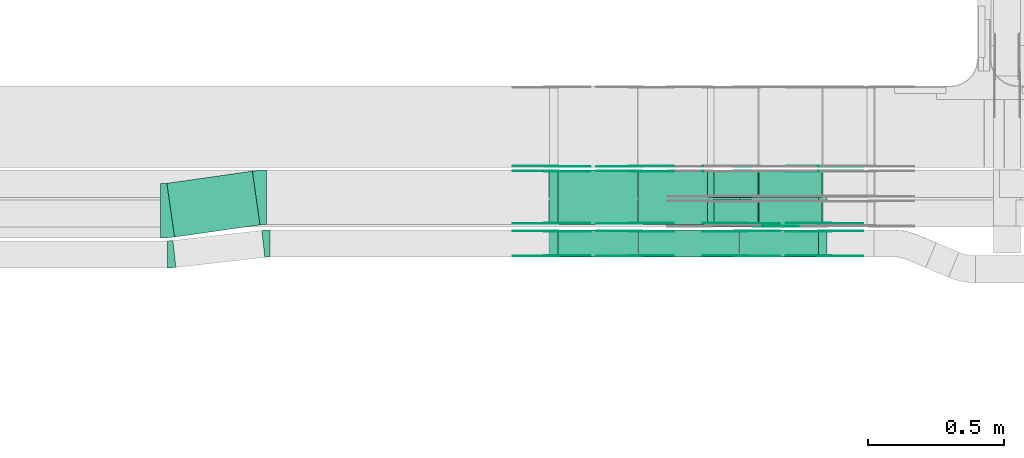
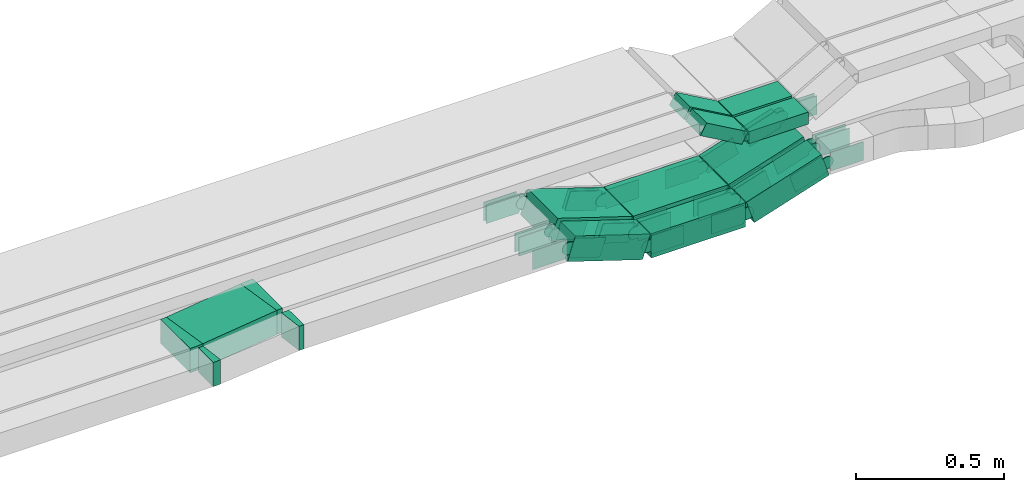
# One storey, part 10 of 27: 45 flow fittings, 11 flow segments.
"""IFC2X3 building model written with IfcOpenShell, lengths in millimetres."""

from ifc_helpers import new_model, entity, si_unit, converted_unit, derived_unit, direction, frame, frame_2d, origin, origin_2d_with_axis, place, context, subcontext, project, spatial, polyline, circle_curve, parameter, trimmed, segment, composite_curve, rectangle, outline, extrude, source, transform, mapped, material, type_object, type_shapes, element, save


model = new_model("IFC2X3")

# Units and contexts
model_context = context("Model", 3, precision=0.01, world=origin(), true_north=direction((6.12303176911189e-17, 1.0)))
body_context = subcontext(model_context, "Body", "Model", "MODEL_VIEW")
ifc_project = project(units=[si_unit("LENGTHUNIT", "METRE", prefix="MILLI"), si_unit("AREAUNIT", "SQUARE_METRE"), si_unit("VOLUMEUNIT", "CUBIC_METRE"), converted_unit("PLANEANGLEUNIT", "DEGREE", entity("IfcRatioMeasure", 0.0174532925199433), si_unit("PLANEANGLEUNIT", "RADIAN"), dimensions=[0, 0, 0, 0, 0, 0, 0]), si_unit("MASSUNIT", "GRAM", prefix="KILO"), derived_unit("MASSDENSITYUNIT", [(si_unit("MASSUNIT", "GRAM", prefix="KILO"), 1), (si_unit("LENGTHUNIT", "METRE"), -3)]), derived_unit("MOMENTOFINERTIAUNIT", [(si_unit("LENGTHUNIT", "METRE"), 4)]), si_unit("TIMEUNIT", "SECOND"), si_unit("FREQUENCYUNIT", "HERTZ"), si_unit("THERMODYNAMICTEMPERATUREUNIT", "DEGREE_CELSIUS"), derived_unit("THERMALTRANSMITTANCEUNIT", [(si_unit("MASSUNIT", "GRAM", prefix="KILO"), 1), (si_unit("THERMODYNAMICTEMPERATUREUNIT", "KELVIN"), -1), (si_unit("TIMEUNIT", "SECOND"), -3)]), derived_unit("VOLUMETRICFLOWRATEUNIT", [(si_unit("LENGTHUNIT", "METRE"), 3), (si_unit("TIMEUNIT", "SECOND"), -1)]), derived_unit("MASSFLOWRATEUNIT", [(si_unit("MASSUNIT", "GRAM", prefix="KILO"), 1), (si_unit("TIMEUNIT", "SECOND"), -1)]), derived_unit("ROTATIONALFREQUENCYUNIT", [(si_unit("TIMEUNIT", "SECOND"), -1)]), si_unit("ELECTRICCURRENTUNIT", "AMPERE"), si_unit("ELECTRICVOLTAGEUNIT", "VOLT"), si_unit("POWERUNIT", "WATT"), si_unit("FORCEUNIT", "NEWTON", prefix="KILO"), si_unit("ILLUMINANCEUNIT", "LUX"), si_unit("LUMINOUSFLUXUNIT", "LUMEN"), si_unit("LUMINOUSINTENSITYUNIT", "CANDELA"), derived_unit("USERDEFINED", [(si_unit("MASSUNIT", "GRAM", prefix="KILO"), -1), (si_unit("LENGTHUNIT", "METRE"), -2), (si_unit("TIMEUNIT", "SECOND"), 3), (si_unit("LUMINOUSFLUXUNIT", "LUMEN"), 1)]), derived_unit("LINEARVELOCITYUNIT", [(si_unit("LENGTHUNIT", "METRE"), 1), (si_unit("TIMEUNIT", "SECOND"), -1)]), si_unit("PRESSUREUNIT", "PASCAL"), derived_unit("USERDEFINED", [(si_unit("LENGTHUNIT", "METRE"), -2), (si_unit("MASSUNIT", "GRAM", prefix="KILO"), 1), (si_unit("TIMEUNIT", "SECOND"), -2)]), derived_unit("LINEARFORCEUNIT", [(si_unit("MASSUNIT", "GRAM", prefix="KILO"), 1), (si_unit("LENGTHUNIT", "METRE"), 1), (si_unit("TIMEUNIT", "SECOND"), -2), (si_unit("LENGTHUNIT", "METRE"), -1)]), derived_unit("PLANARFORCEUNIT", [(si_unit("MASSUNIT", "GRAM", prefix="KILO"), 1), (si_unit("LENGTHUNIT", "METRE"), 1), (si_unit("TIMEUNIT", "SECOND"), -2), (si_unit("LENGTHUNIT", "METRE"), -2)])], contexts=[model_context])

# Site, building, storey
site_placement = place(None, origin())
site = spatial("IfcSite", under=ifc_project, at=site_placement, CompositionType="ELEMENT")
building_placement = place(site_placement, origin())
building = spatial("IfcBuilding", under=site, at=building_placement, CompositionType="ELEMENT")
storey_placement = place(building_placement, origin())
storey = spatial("IfcBuildingStorey", under=building, at=storey_placement, CompositionType="ELEMENT", Elevation=0.0)

# Flow segments
cable_carrier_segment_type = type_object("IfcCableCarrierSegmentType", PredefinedType="CABLETRAYSEGMENT")
flow_segment_1_placement = place(storey_placement, frame((34617.95, 8410.17, 2505.31)))
element("IfcFlowSegment", 1, at=flow_segment_1_placement, inside=storey, type_object=cable_carrier_segment_type, context=body_context, shape_type="SweptSolid", body=[
    extrude(rectangle(XDim=100.0, YDim=200.0, at=origin_2d_with_axis()), frame((15.33, 100.0, 47.59), z_axis=(0.951851431099374, 0.0, 0.306559705626938), x_axis=(-0.306559705626938, 0.0, 0.951851431099374)), (0.0, 0.0, 1.0), 307.238144539815),
])
flow_segment_2_placement = place(storey_placement, frame((34246.11, 8410.17, 2500.0)))
element("IfcFlowSegment", 2, at=flow_segment_2_placement, inside=storey, type_object=cable_carrier_segment_type, context=body_context, shape_type="SweptSolid", body=[
    extrude(rectangle(XDim=368.667780058814, YDim=200.0, at=origin_2d_with_axis()), frame((184.33, 100.0, 0.0), z_axis=(0.0, 0.0, 1.0), x_axis=(-1.0, 0.0, 0.0)), (0.0, 0.0, 1.0), 100.000000000001),
])
flow_segment_3_placement = place(storey_placement, frame((33919.83, 8410.17, 2505.31)))
element("IfcFlowSegment", 3, at=flow_segment_3_placement, inside=storey, type_object=cable_carrier_segment_type, context=body_context, shape_type="SweptSolid", body=[
    extrude(rectangle(XDim=100.0, YDim=200.0, at=frame_2d((0.0, 0.0), x_axis=(0.0, 1.0))), frame((15.33, 100.0, 141.78), z_axis=(0.951851431099359, 0.0, -0.306559705626982), x_axis=(0.0, 1.0, 0.0)), (0.0, 0.0, 1.0), 307.2381445398),
])
flow_segment_4_placement = place(storey_placement, frame((34617.95, 8290.0, 2505.31)))
element("IfcFlowSegment", 4, at=flow_segment_4_placement, inside=storey, type_object=cable_carrier_segment_type, context=body_context, shape_type="SweptSolid", body=[
    extrude(rectangle(XDim=99.9999999999997, YDim=99.9999999999989, at=origin_2d_with_axis()), frame((15.33, 50.0, 47.59), z_axis=(0.951851431099373, 0.0, 0.306559705626939), x_axis=(-0.306559705626939, 0.0, 0.951851431099373)), (0.0, 0.0, 1.0), 307.238144539829),
])
flow_segment_5_placement = place(storey_placement, frame((34246.11, 8290.0, 2500.0)))
element("IfcFlowSegment", 5, at=flow_segment_5_placement, inside=storey, type_object=cable_carrier_segment_type, context=body_context, shape_type="SweptSolid", body=[
    extrude(rectangle(XDim=368.667780058814, YDim=99.9999999999989, at=origin_2d_with_axis()), frame((184.33, 50.0, 0.0), z_axis=(0.0, 0.0, 1.0), x_axis=(-1.0, 0.0, 0.0)), (0.0, 0.0, 1.0), 99.9999999999995),
])
flow_segment_6_placement = place(storey_placement, frame((33919.83, 8290.0, 2505.31)))
element("IfcFlowSegment", 6, at=flow_segment_6_placement, inside=storey, type_object=cable_carrier_segment_type, context=body_context, shape_type="SweptSolid", body=[
    extrude(rectangle(XDim=99.9999999999985, YDim=99.9999999999989, at=frame_2d((0.0, 0.0), x_axis=(0.0, 1.0))), frame((15.33, 50.0, 141.78), z_axis=(0.95185143109933, 0.0, -0.306559705627073), x_axis=(0.0, 1.0, 0.0)), (0.0, 0.0, 1.0), 307.238144539648),
])
flow_segment_7_placement = place(storey_placement, frame((32510.43, 8363.64, 2600.0)))
element("IfcFlowSegment", 7, at=flow_segment_7_placement, inside=storey, type_object=cable_carrier_segment_type, context=body_context, shape_type="SweptSolid", body=[
    extrude(rectangle(XDim=318.01224938673, YDim=200.000000000001, at=origin_2d_with_axis()), frame((171.53, 121.44, 0.0), z_axis=(0.0, 0.0, 1.0), x_axis=(0.989989640110311, 0.141140045608103, 0.0)), (0.0, 0.0, 1.0), 100.0),
])
flow_segment_8_placement = place(storey_placement, frame((34501.22, 8400.0, 2756.67)))
element("IfcFlowSegment", 8, at=flow_segment_8_placement, inside=storey, type_object=cable_carrier_segment_type, context=body_context, shape_type="SweptSolid", body=[
    extrude(rectangle(XDim=49.999999999999, YDim=100.000000000001, at=frame_2d((0.0, 0.0), x_axis=(0.0, 1.0))), frame((12.37, 50.0, 114.03), z_axis=(0.869016356406197, 0.0, -0.494783358954703), x_axis=(0.0, 1.0, 0.0)), (0.0, 0.0, 1.0), 186.565135152812),
])
flow_segment_9_placement = place(storey_placement, frame((34691.93, 8400.0, 2749.1)))
element("IfcFlowSegment", 9, at=flow_segment_9_placement, inside=storey, type_object=cable_carrier_segment_type, context=body_context, shape_type="SweptSolid", body=[
    extrude(rectangle(XDim=231.322850808314, YDim=100.000000000001, at=origin_2d_with_axis()), frame((115.66, 50.0, 0.0)), (0.0, 0.0, 1.0), 49.9999999999989),
])
flow_segment_10_placement = place(storey_placement, frame((34501.22, 8510.0, 2756.67)))
element("IfcFlowSegment", 10, at=flow_segment_10_placement, inside=storey, type_object=cable_carrier_segment_type, context=body_context, shape_type="SweptSolid", body=[
    extrude(rectangle(XDim=50.0000000000032, YDim=100.000000000001, at=frame_2d((0.0, 0.0), x_axis=(0.0, 1.0))), frame((12.37, 50.0, 114.03), z_axis=(0.869016356406319, 0.0, -0.494783358954488), x_axis=(0.0, 1.0, 0.0)), (0.0, 0.0, 1.0), 186.565135152928),
])
flow_segment_11_placement = place(storey_placement, frame((34691.93, 8510.0, 2749.1)))
element("IfcFlowSegment", 11, at=flow_segment_11_placement, inside=storey, type_object=cable_carrier_segment_type, context=body_context, shape_type="SweptSolid", body=[
    extrude(rectangle(XDim=231.322850808314, YDim=100.000000000001, at=origin_2d_with_axis()), frame((115.66, 50.0, 0.0)), (0.0, 0.0, 1.0), 49.9999999999989),
])

# Flow fittings
ifc_material_1 = material(Name="G")
cable_carrier_fitting_type_1 = type_object("IfcCableCarrierFittingType", PredefinedType="NOTDEFINED", material=ifc_material_1)
shared_shape_1 = source(origin(), body_context, "Body", "SweptSolid", [
    extrude(outline(composite_curve([segment(trimmed(circle_curve(frame_2d((-44.59, 0.0), x_axis=(1.0, 0.0)), 12.5), [parameter(90.0000000000007)], [parameter(270.0)], True, "PARAMETER"), True, "CONTINUOUS"), segment(polyline([(-44.59, -12.5), (-33.09, -12.5)]), True, "CONTINUOUS"), segment(polyline([(-33.09, -12.5), (-31.23, -14.5)]), True, "CONTINUOUS"), segment(polyline([(-31.23, -14.5), (108.91, -14.5)]), True, "CONTINUOUS"), segment(polyline([(108.91, -14.5), (108.91, 14.5)]), True, "CONTINUOUS"), segment(polyline([(108.91, 14.5), (-31.23, 14.5)]), True, "CONTINUOUS"), segment(polyline([(-31.23, 14.5), (-33.09, 12.5)]), True, "CONTINUOUS"), segment(polyline([(-33.09, 12.5), (-44.59, 12.5)]), True, "CONTINUOUS")], self_intersect=False)), frame((44.59, 0.0, 0.0), z_axis=(0.0, 0.0, -1.0), x_axis=(1.0, 0.0, 0.0)), (0.0, 0.0, -1.0), 2.0),
])
type_shapes(cable_carrier_fitting_type_1, [shared_shape_1])
flow_fitting_1_placement = place(storey_placement, frame((34683.26, 8404.54, 2774.1), z_axis=(0.0, -1.0, 0.0), x_axis=(1.0, 0.0, 0.0)))
element("IfcFlowFitting", 12, at=flow_fitting_1_placement, inside=storey, type_object=cable_carrier_fitting_type_1, material=ifc_material_1, context=body_context, shape_type="MappedRepresentation", body=[
    mapped(shared_shape_1, transform((0.0, 0.0, 0.0), scale=1.0)),
])
cable_carrier_fitting_type_2 = type_object("IfcCableCarrierFittingType", PredefinedType="NOTDEFINED", material=ifc_material_1)
shared_shape_2 = source(origin(), body_context, "Body", "SweptSolid", [
    extrude(outline(composite_curve([segment(trimmed(circle_curve(frame_2d((-41.47, 0.0), x_axis=(1.0, 0.0)), 25.0), [parameter(90.0000000000007)], [parameter(270.0)], True, "PARAMETER"), True, "CONTINUOUS"), segment(polyline([(-41.47, -25.0), (-29.97, -25.0)]), True, "CONTINUOUS"), segment(polyline([(-29.97, -25.0), (-28.1, -38.5)]), True, "CONTINUOUS"), segment(polyline([(-28.1, -38.5), (99.53, -38.5)]), True, "CONTINUOUS"), segment(polyline([(99.53, -38.5), (99.53, 38.5)]), True, "CONTINUOUS"), segment(polyline([(99.53, 38.5), (-28.1, 38.5)]), True, "CONTINUOUS"), segment(polyline([(-28.1, 38.5), (-29.97, 25.0)]), True, "CONTINUOUS"), segment(polyline([(-29.97, 25.0), (-41.47, 25.0)]), True, "CONTINUOUS")], self_intersect=False)), frame((41.47, 0.0, 0.0), z_axis=(0.0, 0.0, -1.0), x_axis=(1.0, 0.0, 0.0)), (0.0, 0.0, -1.0), 2.0),
])
type_shapes(cable_carrier_fitting_type_2, [shared_shape_2])
flow_fitting_2_placement = place(storey_placement, frame((34624.25, 8624.54, 2550.0), z_axis=(0.0, -1.0, 0.0), x_axis=(0.951851431099356, 0.0, 0.306559705626994)))
element("IfcFlowFitting", 13, at=flow_fitting_2_placement, inside=storey, type_object=cable_carrier_fitting_type_2, material=ifc_material_1, context=body_context, shape_type="MappedRepresentation", body=[
    mapped(shared_shape_2, transform((0.0, 0.0, 0.0), scale=1.0)),
])
cable_carrier_fitting_type_3 = type_object("IfcCableCarrierFittingType", PredefinedType="NOTDEFINED", material=ifc_material_1)
type_shapes(cable_carrier_fitting_type_3, [shared_shape_2])
for number, where, z_axis, x_axis in (
    (14, (33926.13, 8626.54, 2650.0), (0.0, -1.0, 0.0), (-1.0, 0.0, 0.0)),
    (15, (34236.62, 8626.54, 2550.0), (0.0, -1.0, 0.0), (1.0, 0.0, 0.0)),
):
    element("IfcFlowFitting", number, at=place(storey_placement, frame(where, z_axis=z_axis, x_axis=x_axis)), inside=storey, type_object=cable_carrier_fitting_type_3, material=ifc_material_1, context=body_context, shape_type="MappedRepresentation", body=[
        mapped(shared_shape_2, transform((0.0, 0.0, 0.0), scale=1.0)),
    ])
flow_fitting_3_placement = place(storey_placement, frame((34624.25, 8414.71, 2550.0), z_axis=(0.0, -1.0, 0.0), x_axis=(0.951851431099356, 0.0, 0.306559705626994)))
element("IfcFlowFitting", 16, at=flow_fitting_3_placement, inside=storey, type_object=cable_carrier_fitting_type_2, material=ifc_material_1, context=body_context, shape_type="MappedRepresentation", body=[
    mapped(shared_shape_2, transform((0.0, 0.0, 0.0), scale=1.0)),
])
flow_fitting_4_placement = place(storey_placement, frame((34624.25, 8603.63, 2550.0), z_axis=(0.0, 1.0, 0.0), x_axis=(-1.0, 0.0, 0.0)))
element("IfcFlowFitting", 17, at=flow_fitting_4_placement, inside=storey, type_object=cable_carrier_fitting_type_3, material=ifc_material_1, context=body_context, shape_type="MappedRepresentation", body=[
    mapped(shared_shape_2, transform((0.0, 0.0, 0.0), scale=1.0)),
])
flow_fitting_5_placement = place(storey_placement, frame((34236.62, 8605.63, 2550.0), z_axis=(0.0, 1.0, 0.0), x_axis=(-0.951851431099356, 0.0, 0.306559705626994)))
element("IfcFlowFitting", 18, at=flow_fitting_5_placement, inside=storey, type_object=cable_carrier_fitting_type_2, material=ifc_material_1, context=body_context, shape_type="MappedRepresentation", body=[
    mapped(shared_shape_2, transform((0.0, 0.0, 0.0), scale=1.0)),
])
flow_fitting_6_placement = place(storey_placement, frame((34236.62, 8416.71, 2550.0), z_axis=(0.0, -1.0, 0.0), x_axis=(1.0, 0.0, 0.0)))
element("IfcFlowFitting", 19, at=flow_fitting_6_placement, inside=storey, type_object=cable_carrier_fitting_type_3, material=ifc_material_1, context=body_context, shape_type="MappedRepresentation", body=[
    mapped(shared_shape_2, transform((0.0, 0.0, 0.0), scale=1.0)),
])
flow_fitting_7_placement = place(storey_placement, frame((34624.25, 8294.54, 2550.0), z_axis=(0.0, -1.0, 0.0), x_axis=(0.951851431099356, 0.0, 0.306559705626994)))
element("IfcFlowFitting", 20, at=flow_fitting_7_placement, inside=storey, type_object=cable_carrier_fitting_type_2, material=ifc_material_1, context=body_context, shape_type="MappedRepresentation", body=[
    mapped(shared_shape_2, transform((0.0, 0.0, 0.0), scale=1.0)),
])
flow_fitting_8_placement = place(storey_placement, frame((34624.25, 8383.46, 2550.0), z_axis=(0.0, 1.0, 0.0), x_axis=(-1.0, 0.0, 0.0)))
element("IfcFlowFitting", 21, at=flow_fitting_8_placement, inside=storey, type_object=cable_carrier_fitting_type_3, material=ifc_material_1, context=body_context, shape_type="MappedRepresentation", body=[
    mapped(shared_shape_2, transform((0.0, 0.0, 0.0), scale=1.0)),
])
flow_fitting_9_placement = place(storey_placement, frame((34236.62, 8385.46, 2550.0), z_axis=(0.0, 1.0, 0.0), x_axis=(-0.951851431099356, 0.0, 0.306559705626994)))
element("IfcFlowFitting", 22, at=flow_fitting_9_placement, inside=storey, type_object=cable_carrier_fitting_type_2, material=ifc_material_1, context=body_context, shape_type="MappedRepresentation", body=[
    mapped(shared_shape_2, transform((0.0, 0.0, 0.0), scale=1.0)),
])
flow_fitting_10_placement = place(storey_placement, frame((34236.62, 8296.54, 2550.0), z_axis=(0.0, -1.0, 0.0), x_axis=(1.0, 0.0, 0.0)))
element("IfcFlowFitting", 23, at=flow_fitting_10_placement, inside=storey, type_object=cable_carrier_fitting_type_3, material=ifc_material_1, context=body_context, shape_type="MappedRepresentation", body=[
    mapped(shared_shape_2, transform((0.0, 0.0, 0.0), scale=1.0)),
])
flow_fitting_11_placement = place(storey_placement, frame((34934.75, 8385.46, 2650.0), z_axis=(0.0, 1.0, 0.0), x_axis=(1.0, 0.0, 0.0)))
element("IfcFlowFitting", 24, at=flow_fitting_11_placement, inside=storey, type_object=cable_carrier_fitting_type_2, material=ifc_material_1, context=body_context, shape_type="MappedRepresentation", body=[
    mapped(shared_shape_2, transform((0.0, 0.0, 0.0), scale=1.0)),
])
flow_fitting_12_placement = place(storey_placement, frame((34934.75, 8296.54, 2650.0), z_axis=(0.0, -1.0, 0.0), x_axis=(-0.951851431099383, 0.0, -0.306559705626907)))
element("IfcFlowFitting", 25, at=flow_fitting_12_placement, inside=storey, type_object=cable_carrier_fitting_type_3, material=ifc_material_1, context=body_context, shape_type="MappedRepresentation", body=[
    mapped(shared_shape_2, transform((0.0, 0.0, 0.0), scale=1.0)),
])
flow_fitting_13_placement = place(storey_placement, frame((34934.75, 8605.63, 2650.0), z_axis=(0.0, 1.0, 0.0), x_axis=(1.0, 0.0, 0.0)))
element("IfcFlowFitting", 26, at=flow_fitting_13_placement, inside=storey, type_object=cable_carrier_fitting_type_2, material=ifc_material_1, context=body_context, shape_type="MappedRepresentation", body=[
    mapped(shared_shape_2, transform((0.0, 0.0, 0.0), scale=1.0)),
])
for number, where, z_axis, x_axis in (
    (27, (34934.75, 8416.71, 2650.0), (0.0, -1.0, 0.0), (-0.951851431099383, 0.0, -0.306559705626908)),
    (28, (34934.75, 8626.54, 2650.0), (0.0, -1.0, 0.0), (-0.951851431099383, 0.0, -0.306559705626908)),
):
    element("IfcFlowFitting", number, at=place(storey_placement, frame(where, z_axis=z_axis, x_axis=x_axis)), inside=storey, type_object=cable_carrier_fitting_type_3, material=ifc_material_1, context=body_context, shape_type="MappedRepresentation", body=[
        mapped(shared_shape_2, transform((0.0, 0.0, 0.0), scale=1.0)),
    ])
flow_fitting_14_placement = place(storey_placement, frame((33926.13, 8414.71, 2650.0), z_axis=(0.0, -1.0, 0.0), x_axis=(-1.0, 0.0, 0.0)))
element("IfcFlowFitting", 29, at=flow_fitting_14_placement, inside=storey, type_object=cable_carrier_fitting_type_2, material=ifc_material_1, context=body_context, shape_type="MappedRepresentation", body=[
    mapped(shared_shape_2, transform((0.0, 0.0, 0.0), scale=1.0)),
])
flow_fitting_15_placement = place(storey_placement, frame((33926.13, 8603.63, 2650.0), z_axis=(0.0, 1.0, 0.0), x_axis=(0.951851431099373, 0.0, -0.306559705626939)))
element("IfcFlowFitting", 30, at=flow_fitting_15_placement, inside=storey, type_object=cable_carrier_fitting_type_3, material=ifc_material_1, context=body_context, shape_type="MappedRepresentation", body=[
    mapped(shared_shape_2, transform((0.0, 0.0, 0.0), scale=1.0)),
])
flow_fitting_16_placement = place(storey_placement, frame((33926.13, 8294.54, 2650.0), z_axis=(0.0, -1.0, 0.0), x_axis=(-1.0, 0.0, 0.0)))
element("IfcFlowFitting", 31, at=flow_fitting_16_placement, inside=storey, type_object=cable_carrier_fitting_type_2, material=ifc_material_1, context=body_context, shape_type="MappedRepresentation", body=[
    mapped(shared_shape_2, transform((0.0, 0.0, 0.0), scale=1.0)),
])
flow_fitting_17_placement = place(storey_placement, frame((33926.13, 8383.46, 2650.0), z_axis=(0.0, 1.0, 0.0), x_axis=(0.951851431099337, 0.0, -0.306559705627052)))
element("IfcFlowFitting", 32, at=flow_fitting_17_placement, inside=storey, type_object=cable_carrier_fitting_type_3, material=ifc_material_1, context=body_context, shape_type="MappedRepresentation", body=[
    mapped(shared_shape_2, transform((0.0, 0.0, 0.0), scale=1.0)),
])
cable_carrier_fitting_type_4 = type_object("IfcCableCarrierFittingType", PredefinedType="NOTDEFINED", material=ifc_material_1)
shared_shape_3 = source(origin(), body_context, "Body", "SweptSolid", [
    extrude(outline(composite_curve([segment(trimmed(circle_curve(frame_2d((-41.47, 0.0), x_axis=(1.0, 0.0)), 25.0), [parameter(90.0000000000007)], [parameter(270.0)], True, "PARAMETER"), True, "CONTINUOUS"), segment(polyline([(-41.47, -25.0), (-29.97, -25.0)]), True, "CONTINUOUS"), segment(polyline([(-29.97, -25.0), (-28.1, -38.5)]), True, "CONTINUOUS"), segment(polyline([(-28.1, -38.5), (99.53, -38.5)]), True, "CONTINUOUS"), segment(polyline([(99.53, -38.5), (99.53, 38.5)]), True, "CONTINUOUS"), segment(polyline([(99.53, 38.5), (-28.1, 38.5)]), True, "CONTINUOUS"), segment(polyline([(-28.1, 38.5), (-29.97, 25.0)]), True, "CONTINUOUS"), segment(polyline([(-29.97, 25.0), (-41.47, 25.0)]), True, "CONTINUOUS")], self_intersect=False)), frame((41.47, 0.0, 0.0)), (0.0, 0.0, 1.0), 2.0),
])
type_shapes(cable_carrier_fitting_type_4, [shared_shape_3])
flow_fitting_18_placement = place(storey_placement, frame((34624.25, 8626.54, 2550.0), z_axis=(0.0, -1.0, 0.0), x_axis=(-1.0, 0.0, 0.0)))
element("IfcFlowFitting", 33, at=flow_fitting_18_placement, inside=storey, type_object=cable_carrier_fitting_type_4, material=ifc_material_1, context=body_context, shape_type="MappedRepresentation", body=[
    mapped(shared_shape_3, transform((0.0, 0.0, 0.0), scale=1.0)),
])
cable_carrier_fitting_type_5 = type_object("IfcCableCarrierFittingType", PredefinedType="NOTDEFINED", material=ifc_material_1)
type_shapes(cable_carrier_fitting_type_5, [shared_shape_3])
for number, where, z_axis, x_axis in (
    (34, (33926.13, 8624.54, 2650.0), (0.0, -1.0, 0.0), (0.951851431099356, 0.0, -0.306559705626994)),
    (35, (34236.62, 8624.54, 2550.0), (0.0, -1.0, 0.0), (-0.951851431099356, 0.0, 0.306559705626994)),
    (36, (34624.25, 8605.63, 2550.0), (0.0, 1.0, 0.0), (0.951851431099356, 0.0, 0.306559705626994)),
):
    element("IfcFlowFitting", number, at=place(storey_placement, frame(where, z_axis=z_axis, x_axis=x_axis)), inside=storey, type_object=cable_carrier_fitting_type_5, material=ifc_material_1, context=body_context, shape_type="MappedRepresentation", body=[
        mapped(shared_shape_3, transform((0.0, 0.0, 0.0), scale=1.0)),
    ])
flow_fitting_19_placement = place(storey_placement, frame((34624.25, 8416.71, 2550.0), z_axis=(0.0, -1.0, 0.0), x_axis=(-1.0, 0.0, 0.0)))
element("IfcFlowFitting", 37, at=flow_fitting_19_placement, inside=storey, type_object=cable_carrier_fitting_type_4, material=ifc_material_1, context=body_context, shape_type="MappedRepresentation", body=[
    mapped(shared_shape_3, transform((0.0, 0.0, 0.0), scale=1.0)),
])
flow_fitting_20_placement = place(storey_placement, frame((34236.62, 8414.71, 2550.0), z_axis=(0.0, -1.0, 0.0), x_axis=(-0.951851431099356, 0.0, 0.306559705626994)))
element("IfcFlowFitting", 38, at=flow_fitting_20_placement, inside=storey, type_object=cable_carrier_fitting_type_5, material=ifc_material_1, context=body_context, shape_type="MappedRepresentation", body=[
    mapped(shared_shape_3, transform((0.0, 0.0, 0.0), scale=1.0)),
])
flow_fitting_21_placement = place(storey_placement, frame((34236.62, 8603.63, 2550.0), z_axis=(0.0, 1.0, 0.0), x_axis=(1.0, 0.0, 0.0)))
element("IfcFlowFitting", 39, at=flow_fitting_21_placement, inside=storey, type_object=cable_carrier_fitting_type_4, material=ifc_material_1, context=body_context, shape_type="MappedRepresentation", body=[
    mapped(shared_shape_3, transform((0.0, 0.0, 0.0), scale=1.0)),
])
flow_fitting_22_placement = place(storey_placement, frame((34624.25, 8385.46, 2550.0), z_axis=(0.0, 1.0, 0.0), x_axis=(0.951851431099356, 0.0, 0.306559705626994)))
element("IfcFlowFitting", 40, at=flow_fitting_22_placement, inside=storey, type_object=cable_carrier_fitting_type_5, material=ifc_material_1, context=body_context, shape_type="MappedRepresentation", body=[
    mapped(shared_shape_3, transform((0.0, 0.0, 0.0), scale=1.0)),
])
flow_fitting_23_placement = place(storey_placement, frame((34624.25, 8296.54, 2550.0), z_axis=(0.0, -1.0, 0.0), x_axis=(-1.0, 0.0, 0.0)))
element("IfcFlowFitting", 41, at=flow_fitting_23_placement, inside=storey, type_object=cable_carrier_fitting_type_4, material=ifc_material_1, context=body_context, shape_type="MappedRepresentation", body=[
    mapped(shared_shape_3, transform((0.0, 0.0, 0.0), scale=1.0)),
])
flow_fitting_24_placement = place(storey_placement, frame((34236.62, 8294.54, 2550.0), z_axis=(0.0, -1.0, 0.0), x_axis=(-0.951851431099356, 0.0, 0.306559705626994)))
element("IfcFlowFitting", 42, at=flow_fitting_24_placement, inside=storey, type_object=cable_carrier_fitting_type_5, material=ifc_material_1, context=body_context, shape_type="MappedRepresentation", body=[
    mapped(shared_shape_3, transform((0.0, 0.0, 0.0), scale=1.0)),
])
flow_fitting_25_placement = place(storey_placement, frame((34236.62, 8383.46, 2550.0), z_axis=(0.0, 1.0, 0.0), x_axis=(1.0, 0.0, 0.0)))
element("IfcFlowFitting", 43, at=flow_fitting_25_placement, inside=storey, type_object=cable_carrier_fitting_type_4, material=ifc_material_1, context=body_context, shape_type="MappedRepresentation", body=[
    mapped(shared_shape_3, transform((0.0, 0.0, 0.0), scale=1.0)),
])
flow_fitting_26_placement = place(storey_placement, frame((34934.75, 8294.54, 2650.0), z_axis=(0.0, -1.0, 0.0), x_axis=(1.0, 0.0, 0.0)))
element("IfcFlowFitting", 44, at=flow_fitting_26_placement, inside=storey, type_object=cable_carrier_fitting_type_5, material=ifc_material_1, context=body_context, shape_type="MappedRepresentation", body=[
    mapped(shared_shape_3, transform((0.0, 0.0, 0.0), scale=1.0)),
])
flow_fitting_27_placement = place(storey_placement, frame((34934.75, 8383.46, 2650.0), z_axis=(0.0, 1.0, 0.0), x_axis=(-0.951851431099383, 0.0, -0.306559705626907)))
element("IfcFlowFitting", 45, at=flow_fitting_27_placement, inside=storey, type_object=cable_carrier_fitting_type_4, material=ifc_material_1, context=body_context, shape_type="MappedRepresentation", body=[
    mapped(shared_shape_3, transform((0.0, 0.0, 0.0), scale=1.0)),
])
flow_fitting_28_placement = place(storey_placement, frame((34934.75, 8414.71, 2650.0), z_axis=(0.0, -1.0, 0.0), x_axis=(1.0, 0.0, 0.0)))
element("IfcFlowFitting", 46, at=flow_fitting_28_placement, inside=storey, type_object=cable_carrier_fitting_type_5, material=ifc_material_1, context=body_context, shape_type="MappedRepresentation", body=[
    mapped(shared_shape_3, transform((0.0, 0.0, 0.0), scale=1.0)),
])
flow_fitting_29_placement = place(storey_placement, frame((34934.75, 8603.63, 2650.0), z_axis=(0.0, 1.0, 0.0), x_axis=(-0.951851431099383, 0.0, -0.306559705626908)))
element("IfcFlowFitting", 47, at=flow_fitting_29_placement, inside=storey, type_object=cable_carrier_fitting_type_4, material=ifc_material_1, context=body_context, shape_type="MappedRepresentation", body=[
    mapped(shared_shape_3, transform((0.0, 0.0, 0.0), scale=1.0)),
])
for number, where, z_axis, x_axis in (
    (48, (34934.75, 8624.54, 2650.0), (0.0, -1.0, 0.0), (1.0, 0.0, 0.0)),
    (49, (33926.13, 8605.63, 2650.0), (0.0, 1.0, 0.0), (-1.0, 0.0, 0.0)),
):
    element("IfcFlowFitting", number, at=place(storey_placement, frame(where, z_axis=z_axis, x_axis=x_axis)), inside=storey, type_object=cable_carrier_fitting_type_5, material=ifc_material_1, context=body_context, shape_type="MappedRepresentation", body=[
        mapped(shared_shape_3, transform((0.0, 0.0, 0.0), scale=1.0)),
    ])
flow_fitting_30_placement = place(storey_placement, frame((33926.13, 8416.71, 2650.0), z_axis=(0.0, -1.0, 0.0), x_axis=(0.951851431099373, 0.0, -0.306559705626939)))
element("IfcFlowFitting", 50, at=flow_fitting_30_placement, inside=storey, type_object=cable_carrier_fitting_type_4, material=ifc_material_1, context=body_context, shape_type="MappedRepresentation", body=[
    mapped(shared_shape_3, transform((0.0, 0.0, 0.0), scale=1.0)),
])
flow_fitting_31_placement = place(storey_placement, frame((33926.13, 8385.46, 2650.0), z_axis=(0.0, 1.0, 0.0), x_axis=(-1.0, 0.0, 0.0)))
element("IfcFlowFitting", 51, at=flow_fitting_31_placement, inside=storey, type_object=cable_carrier_fitting_type_5, material=ifc_material_1, context=body_context, shape_type="MappedRepresentation", body=[
    mapped(shared_shape_3, transform((0.0, 0.0, 0.0), scale=1.0)),
])
flow_fitting_32_placement = place(storey_placement, frame((33926.13, 8296.54, 2650.0), z_axis=(0.0, -1.0, 0.0), x_axis=(0.951851431099337, 0.0, -0.306559705627052)))
element("IfcFlowFitting", 52, at=flow_fitting_32_placement, inside=storey, type_object=cable_carrier_fitting_type_4, material=ifc_material_1, context=body_context, shape_type="MappedRepresentation", body=[
    mapped(shared_shape_3, transform((0.0, 0.0, 0.0), scale=1.0)),
])
ifc_material_2 = material()
cable_carrier_fitting_type_6 = type_object("IfcCableCarrierFittingType", Name="470_DKC_S5_Variable Angle Elbow 0-45:-", PredefinedType="NOTDEFINED", material=ifc_material_2)
shared_shape_4 = source(origin(), body_context, "Body", "SweptSolid", [
    extrude(outline(composite_curve([segment(polyline([(-12.29, -50.67), (-11.29, -50.67)]), True, "CONTINUOUS"), segment(trimmed(circle_curve(frame_2d((-11.29, 199.33), x_axis=(0.0, -1.0)), 250.0), [parameter(0.0)], [parameter(6.4846020101254)], True, "PARAMETER"), True, "CONTINUOUS"), segment(polyline([(16.94, -49.07), (17.94, -48.96)]), True, "CONTINUOUS"), segment(polyline([(17.94, -48.96), (6.64, 50.4)]), True, "CONTINUOUS"), segment(polyline([(6.64, 50.4), (5.65, 50.29)]), True, "CONTINUOUS"), segment(trimmed(circle_curve(frame_2d((-11.29, 199.33), x_axis=(0.0, -1.0)), 150.0), [parameter(0.0)], [parameter(6.4846020101254)], True, "PARAMETER"), False, "CONTINUOUS"), segment(polyline([(-11.29, 49.33), (-12.29, 49.33)]), True, "CONTINUOUS"), segment(polyline([(-12.29, 49.33), (-12.29, -50.67)]), True, "CONTINUOUS")], self_intersect=False)), frame((-0.04, 0.67, -50.0)), (0.0, 0.0, 1.0), 100.0),
])
type_shapes(cable_carrier_fitting_type_6, [shared_shape_4])
flow_fitting_33_placement = place(storey_placement, frame((32877.92, 8340.0, 2650.0), z_axis=(0.0, 0.0, 1.0), x_axis=(-1.0, 0.0, 0.0)))
element("IfcFlowFitting", 53, at=flow_fitting_33_placement, inside=storey, type_object=cable_carrier_fitting_type_6, material=ifc_material_2, Name="470_DKC_S5_Variable Angle Elbow 0-45:-", ObjectType="470_DKC_S5_Variable Angle Elbow 0-45:-", context=body_context, shape_type="MappedRepresentation", body=[
    mapped(shared_shape_4, transform((0.0, 0.0, 0.0), scale=1.0)),
])
flow_fitting_34_placement = place(storey_placement, frame((32526.0, 8300.0, 2650.0)))
element("IfcFlowFitting", 54, at=flow_fitting_34_placement, inside=storey, type_object=cable_carrier_fitting_type_6, material=ifc_material_2, Name="470_DKC_S5_Variable Angle Elbow 0-45:-", ObjectType="470_DKC_S5_Variable Angle Elbow 0-45:-", context=body_context, shape_type="MappedRepresentation", body=[
    mapped(shared_shape_4, transform((0.0, 0.0, 0.0), scale=1.0)),
])
cable_carrier_fitting_type_7 = type_object("IfcCableCarrierFittingType", Name="470_DKC_S5_Variable Angle Elbow 0-45:-", PredefinedType="NOTDEFINED", material=ifc_material_2)
shared_shape_5 = source(origin(), body_context, "Body", "SweptSolid", [
    extrude(outline(composite_curve([segment(polyline([(-18.64, -101.29), (-17.64, -101.29)]), True, "CONTINUOUS"), segment(trimmed(circle_curve(frame_2d((-17.64, 248.71), x_axis=(0.0, -1.0)), 350.0), [parameter(0.0)], [parameter(8.11382113479331)], True, "PARAMETER"), True, "CONTINUOUS"), segment(polyline([(31.76, -97.78), (32.75, -97.64)]), True, "CONTINUOUS"), segment(polyline([(32.75, -97.64), (4.52, 100.36)]), True, "CONTINUOUS"), segment(polyline([(4.52, 100.36), (3.53, 100.21)]), True, "CONTINUOUS"), segment(trimmed(circle_curve(frame_2d((-17.64, 248.71), x_axis=(0.0, -1.0)), 150.0), [parameter(0.0)], [parameter(8.11382113479331)], True, "PARAMETER"), False, "CONTINUOUS"), segment(polyline([(-17.64, 98.71), (-18.64, 98.71)]), True, "CONTINUOUS"), segment(polyline([(-18.64, 98.71), (-18.64, -101.29)]), True, "CONTINUOUS")], self_intersect=False)), frame((-0.09, 1.29, -50.0)), (0.0, 0.0, 1.0), 100.0),
])
type_shapes(cable_carrier_fitting_type_7, [shared_shape_5])
flow_fitting_35_placement = place(storey_placement, frame((32857.92, 8510.17, 2650.0), z_axis=(0.0, 0.0, 1.0), x_axis=(-1.0, 0.0, 0.0)))
element("IfcFlowFitting", 55, at=flow_fitting_35_placement, inside=storey, type_object=cable_carrier_fitting_type_7, material=ifc_material_2, Name="470_DKC_S5_Variable Angle Elbow 0-45:-", ObjectType="470_DKC_S5_Variable Angle Elbow 0-45:-", context=body_context, shape_type="MappedRepresentation", body=[
    mapped(shared_shape_5, transform((0.0, 0.0, 0.0), scale=1.0)),
])
flow_fitting_36_placement = place(storey_placement, frame((32506.0, 8460.0, 2650.0)))
element("IfcFlowFitting", 56, at=flow_fitting_36_placement, inside=storey, type_object=cable_carrier_fitting_type_7, material=ifc_material_2, Name="470_DKC_S5_Variable Angle Elbow 0-45:-", ObjectType="470_DKC_S5_Variable Angle Elbow 0-45:-", context=body_context, shape_type="MappedRepresentation", body=[
    mapped(shared_shape_5, transform((0.0, 0.0, 0.0), scale=1.0)),
])

save(model, "model.ifc")
